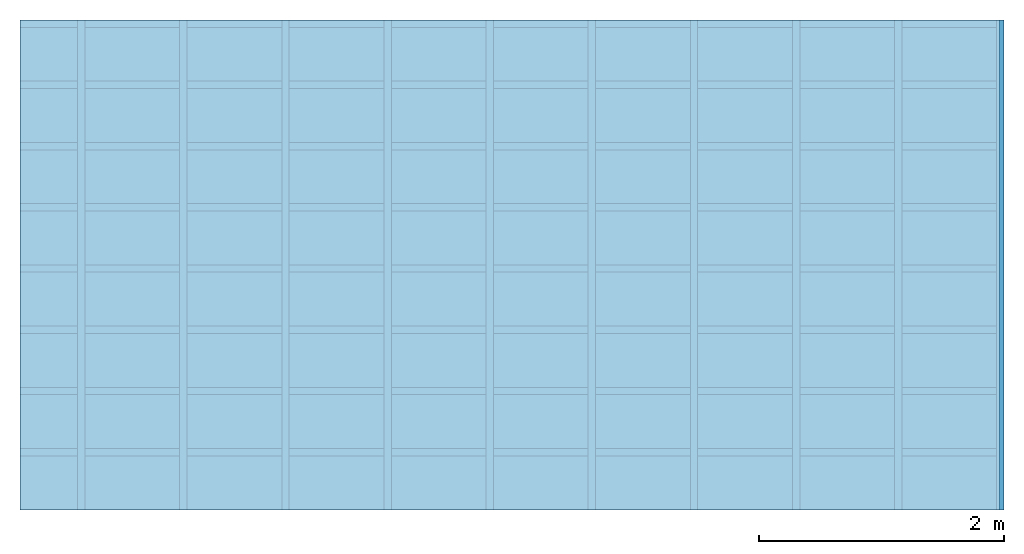
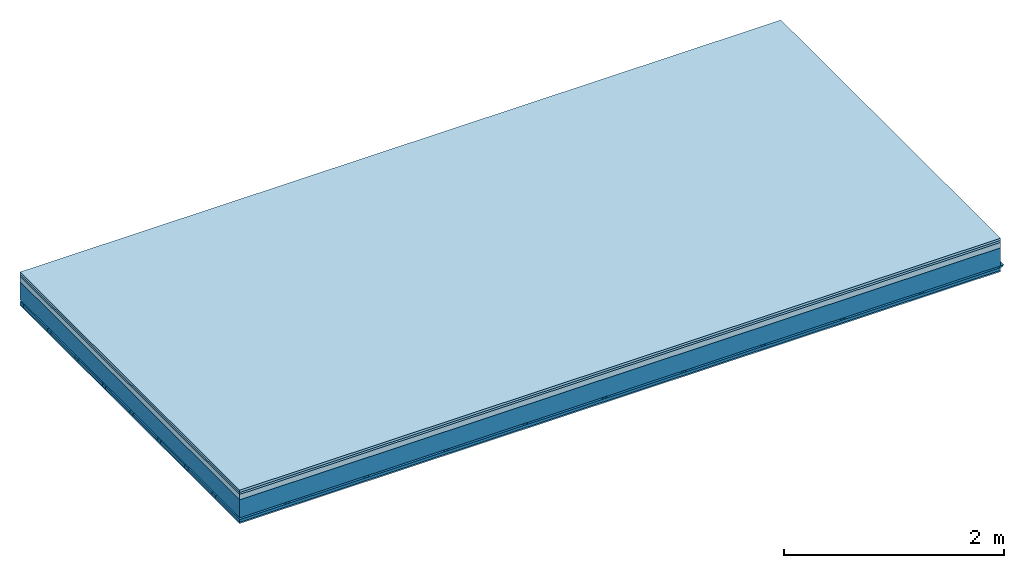
# One storey: 4 members, 4 plates, 1 element without a shape of its own.
"""IFC4 building model written with IfcOpenShell, lengths in metres."""

from ifc_helpers import new_model, si_unit, derived_unit, direction, frame, frame_2d, origin, origin_with_axes, place, context, project, spatial, polyline, rectangle, outline, extrude, material, layer, layer_set, type_object, element, aggregate, save


model = new_model("IFC4")

# Units and contexts
plan_context = context("Plan", 3, precision=1e-05, world=origin(), true_north=direction((0.0, 1.0)))
model_context = context("Model", 3, precision=1e-05, world=origin(), true_north=direction((0.0, 1.0)))
ifc_project = project(units=[si_unit("LENGTHUNIT", "METRE"), derived_unit("SOUNDPRESSUREUNIT", [(si_unit("PRESSUREUNIT", "PASCAL", prefix="MICRO"), 0)]), si_unit("ENERGYUNIT", "JOULE", prefix="MEGA"), si_unit("MASSUNIT", "GRAM", prefix="KILO"), derived_unit("THERMALTRANSMITTANCEUNIT", [(si_unit("POWERUNIT", "WATT"), 1), (si_unit("AREAUNIT", "SQUARE_METRE"), -1), (si_unit("THERMODYNAMICTEMPERATUREUNIT", "KELVIN"), -1)]), derived_unit("AREADENSITYUNIT", [(si_unit("MASSUNIT", "GRAM", prefix="KILO"), 1), (si_unit("AREAUNIT", "SQUARE_METRE"), -1)]), derived_unit("USERDEFINED", [(si_unit("ENERGYUNIT", "JOULE", prefix="MEGA"), 1), (si_unit("AREAUNIT", "SQUARE_METRE"), -1)])], contexts=[plan_context, model_context])

# Site, building, storey
site = spatial("IfcSite", under=ifc_project)
building_placement = place(None, origin())
building = spatial("IfcBuilding", under=site, at=building_placement)
storey_placement = place(building_placement, origin())
storey = spatial("IfcBuildingStorey", under=building, at=storey_placement)

# Slab, members, plates
ifc_material_1 = material(Name="Floor heating system Therm38 longitudinal", Category="03.007")
ifc_layer_1 = layer(ifc_material_1, 0.025, Name="On-material")
ifc_material_2 = material(Category="10.009")
ifc_layer_2 = layer(ifc_material_2, 0.022, Name="Impact sound insulation")
ifc_material_3 = material(Category="03.011")
ifc_layer_3 = layer(ifc_material_3, 0.06, Name="on Supporting structure")
ifc_layer_4 = layer(None, 0.2, Name="Supporting structure")
ifc_material_4 = material(Name="no composite action")
ifc_layer_5 = layer(ifc_material_4, 0.0, Name="Bond")
ifc_layer_6 = layer(None, 0.02, Name="Coupling")
ifc_layer_7 = layer(None, 0.03, Name="Battens / profiles")
ifc_material_5 = material(Category="03.007")
ifc_layer_8 = layer(ifc_material_5, 0.015, Name="Ceiling covering 1st layer")
ifc_material_6 = material(Name="Glued joints")
ifc_layer_9 = layer(ifc_material_6, 0.0, Name="Surface / treatment")
ifc_layer_set = layer_set([ifc_layer_1, ifc_layer_2, ifc_layer_3, ifc_layer_4, ifc_layer_5, ifc_layer_6, ifc_layer_7, ifc_layer_8, ifc_layer_9])
slab_type = type_object("IfcSlabType", Name="A1126", PredefinedType="NOTDEFINED", material=ifc_layer_set)
slab_placement = place(None, frame((0.0, 0.0, 0.0), z_axis=(0.0, 0.0, -1.0), x_axis=(1.0, 0.0, 0.0)))
slab = element("IfcSlab", 1, at=slab_placement, inside=storey, type_object=slab_type, material=ifc_layer_set, Name="Slab #1")
ifc_material_7 = material()
member_1_placement = place(slab_placement, origin())
member_1 = element("IfcMember", 2, at=member_1_placement, material=ifc_material_7, Name="Supporting structure", context=plan_context, shape_type="SweptSolid", body=[
    extrude(rectangle(XDim=1.0, YDim=0.2, at=frame_2d((0.5, 0.1), x_axis=(1.0, 0.0))), frame((0.0, 4.0, 0.107), z_axis=(0.0, -1.0, 0.0), x_axis=(1.0, 0.0, 0.0)), (0.0, 0.0, 1.0), 4.0),
    extrude(rectangle(XDim=1.0, YDim=0.2, at=frame_2d((0.5, 0.1), x_axis=(1.0, 0.0))), frame((1.0, 4.0, 0.107), z_axis=(0.0, -1.0, 0.0), x_axis=(1.0, 0.0, 0.0)), (0.0, 0.0, 1.0), 4.0),
    extrude(rectangle(XDim=1.0, YDim=0.2, at=frame_2d((0.5, 0.1), x_axis=(1.0, 0.0))), frame((2.0, 4.0, 0.107), z_axis=(0.0, -1.0, 0.0), x_axis=(1.0, 0.0, 0.0)), (0.0, 0.0, 1.0), 4.0),
    extrude(rectangle(XDim=1.0, YDim=0.2, at=frame_2d((0.5, 0.1), x_axis=(1.0, 0.0))), frame((3.0, 4.0, 0.107), z_axis=(0.0, -1.0, 0.0), x_axis=(1.0, 0.0, 0.0)), (0.0, 0.0, 1.0), 4.0),
    extrude(rectangle(XDim=1.0, YDim=0.2, at=frame_2d((0.5, 0.1), x_axis=(1.0, 0.0))), frame((4.0, 4.0, 0.107), z_axis=(0.0, -1.0, 0.0), x_axis=(1.0, 0.0, 0.0)), (0.0, 0.0, 1.0), 4.0),
    extrude(rectangle(XDim=1.0, YDim=0.2, at=frame_2d((0.5, 0.1), x_axis=(1.0, 0.0))), frame((5.0, 4.0, 0.107), z_axis=(0.0, -1.0, 0.0), x_axis=(1.0, 0.0, 0.0)), (0.0, 0.0, 1.0), 4.0),
    extrude(rectangle(XDim=1.0, YDim=0.2, at=frame_2d((0.5, 0.1), x_axis=(1.0, 0.0))), frame((6.0, 4.0, 0.107), z_axis=(0.0, -1.0, 0.0), x_axis=(1.0, 0.0, 0.0)), (0.0, 0.0, 1.0), 4.0),
    extrude(rectangle(XDim=1.0, YDim=0.2, at=frame_2d((0.5, 0.1), x_axis=(1.0, 0.0))), frame((7.0, 4.0, 0.107), z_axis=(0.0, -1.0, 0.0), x_axis=(1.0, 0.0, 0.0)), (0.0, 0.0, 1.0), 4.0),
])
ifc_material_8 = material()
member_2_placement = place(slab_placement, origin())
member_2 = element("IfcMember", 3, at=member_2_placement, material=ifc_material_8, Name="Coupling", context=plan_context, shape_type="SweptSolid", body=[
    extrude(outline(polyline([(0.0, 0.0), (0.06, 0.0), (0.04, 0.02), (0.02, 0.02), (0.0, 0.0)])), frame((0.47, 4.0, 0.307), z_axis=(0.0, -1.0, 0.0), x_axis=(1.0, 0.0, 0.0)), (0.0, 0.0, 1.0), 4.0),
    extrude(outline(polyline([(0.0, 0.0), (0.06, 0.0), (0.04, 0.02), (0.02, 0.02), (0.0, 0.0)])), frame((1.304, 4.0, 0.307), z_axis=(0.0, -1.0, 0.0), x_axis=(1.0, 0.0, 0.0)), (0.0, 0.0, 1.0), 4.0),
    extrude(outline(polyline([(0.0, 0.0), (0.06, 0.0), (0.04, 0.02), (0.02, 0.02), (0.0, 0.0)])), frame((2.138, 4.0, 0.307), z_axis=(0.0, -1.0, 0.0), x_axis=(1.0, 0.0, 0.0)), (0.0, 0.0, 1.0), 4.0),
    extrude(outline(polyline([(0.0, 0.0), (0.06, 0.0), (0.04, 0.02), (0.02, 0.02), (0.0, 0.0)])), frame((2.972, 4.0, 0.307), z_axis=(0.0, -1.0, 0.0), x_axis=(1.0, 0.0, 0.0)), (0.0, 0.0, 1.0), 4.0),
    extrude(outline(polyline([(0.0, 0.0), (0.06, 0.0), (0.04, 0.02), (0.02, 0.02), (0.0, 0.0)])), frame((3.806, 4.0, 0.307), z_axis=(0.0, -1.0, 0.0), x_axis=(1.0, 0.0, 0.0)), (0.0, 0.0, 1.0), 4.0),
    extrude(outline(polyline([(0.0, 0.0), (0.06, 0.0), (0.04, 0.02), (0.02, 0.02), (0.0, 0.0)])), frame((4.64, 4.0, 0.307), z_axis=(0.0, -1.0, 0.0), x_axis=(1.0, 0.0, 0.0)), (0.0, 0.0, 1.0), 4.0),
    extrude(outline(polyline([(0.0, 0.0), (0.06, 0.0), (0.04, 0.02), (0.02, 0.02), (0.0, 0.0)])), frame((5.474, 4.0, 0.307), z_axis=(0.0, -1.0, 0.0), x_axis=(1.0, 0.0, 0.0)), (0.0, 0.0, 1.0), 4.0),
    extrude(outline(polyline([(0.0, 0.0), (0.06, 0.0), (0.04, 0.02), (0.02, 0.02), (0.0, 0.0)])), frame((6.308, 4.0, 0.307), z_axis=(0.0, -1.0, 0.0), x_axis=(1.0, 0.0, 0.0)), (0.0, 0.0, 1.0), 4.0),
    extrude(outline(polyline([(0.0, 0.0), (0.06, 0.0), (0.04, 0.02), (0.02, 0.02), (0.0, 0.0)])), frame((7.142, 4.0, 0.307), z_axis=(0.0, -1.0, 0.0), x_axis=(1.0, 0.0, 0.0)), (0.0, 0.0, 1.0), 4.0),
    extrude(outline(polyline([(0.0, 0.0), (0.06, 0.0), (0.04, 0.02), (0.02, 0.02), (0.0, 0.0)])), frame((7.976, 4.0, 0.307), z_axis=(0.0, -1.0, 0.0), x_axis=(1.0, 0.0, 0.0)), (0.0, 0.0, 1.0), 4.0),
])
ifc_material_9 = material()
member_3_placement = place(slab_placement, origin())
member_3 = element("IfcMember", 4, at=member_3_placement, material=ifc_material_9, Name="Battens / profiles", context=plan_context, shape_type="SweptSolid", body=[
    extrude(rectangle(XDim=0.06, YDim=0.03, at=frame_2d((0.03, 0.015), x_axis=(1.0, 0.0))), frame((0.0, 0.0, 0.327), z_axis=(1.0, 0.0, 0.0), x_axis=(0.0, 1.0, 0.0)), (0.0, 0.0, 1.0), 8.0),
    extrude(rectangle(XDim=0.06, YDim=0.03, at=frame_2d((0.03, 0.015), x_axis=(1.0, 0.0))), frame((0.0, 0.5, 0.327), z_axis=(1.0, 0.0, 0.0), x_axis=(0.0, 1.0, 0.0)), (0.0, 0.0, 1.0), 8.0),
    extrude(rectangle(XDim=0.06, YDim=0.03, at=frame_2d((0.03, 0.015), x_axis=(1.0, 0.0))), frame((0.0, 1.0, 0.327), z_axis=(1.0, 0.0, 0.0), x_axis=(0.0, 1.0, 0.0)), (0.0, 0.0, 1.0), 8.0),
    extrude(rectangle(XDim=0.06, YDim=0.03, at=frame_2d((0.03, 0.015), x_axis=(1.0, 0.0))), frame((0.0, 1.5, 0.327), z_axis=(1.0, 0.0, 0.0), x_axis=(0.0, 1.0, 0.0)), (0.0, 0.0, 1.0), 8.0),
    extrude(rectangle(XDim=0.06, YDim=0.03, at=frame_2d((0.03, 0.015), x_axis=(1.0, 0.0))), frame((0.0, 2.0, 0.327), z_axis=(1.0, 0.0, 0.0), x_axis=(0.0, 1.0, 0.0)), (0.0, 0.0, 1.0), 8.0),
    extrude(rectangle(XDim=0.06, YDim=0.03, at=frame_2d((0.03, 0.015), x_axis=(1.0, 0.0))), frame((0.0, 2.5, 0.327), z_axis=(1.0, 0.0, 0.0), x_axis=(0.0, 1.0, 0.0)), (0.0, 0.0, 1.0), 8.0),
    extrude(rectangle(XDim=0.06, YDim=0.03, at=frame_2d((0.03, 0.015), x_axis=(1.0, 0.0))), frame((0.0, 3.0, 0.327), z_axis=(1.0, 0.0, 0.0), x_axis=(0.0, 1.0, 0.0)), (0.0, 0.0, 1.0), 8.0),
    extrude(rectangle(XDim=0.06, YDim=0.03, at=frame_2d((0.03, 0.015), x_axis=(1.0, 0.0))), frame((0.0, 3.5, 0.327), z_axis=(1.0, 0.0, 0.0), x_axis=(0.0, 1.0, 0.0)), (0.0, 0.0, 1.0), 8.0),
])
ifc_material_10 = material()
member_4_placement = place(slab_placement, origin())
member_4 = element("IfcMember", 5, at=member_4_placement, material=ifc_material_10, Name="Cavity", context=plan_context, shape_type="SweptSolid", body=[
    extrude(rectangle(XDim=0.44, YDim=0.03, at=frame_2d((0.22, 0.015), x_axis=(1.0, 0.0))), frame((0.0, 0.06, 0.327), z_axis=(1.0, 0.0, 0.0), x_axis=(0.0, 1.0, 0.0)), (0.0, 0.0, 1.0), 8.0),
    extrude(rectangle(XDim=0.44, YDim=0.03, at=frame_2d((0.22, 0.015), x_axis=(1.0, 0.0))), frame((0.0, 0.56, 0.327), z_axis=(1.0, 0.0, 0.0), x_axis=(0.0, 1.0, 0.0)), (0.0, 0.0, 1.0), 8.0),
    extrude(rectangle(XDim=0.44, YDim=0.03, at=frame_2d((0.22, 0.015), x_axis=(1.0, 0.0))), frame((0.0, 1.06, 0.327), z_axis=(1.0, 0.0, 0.0), x_axis=(0.0, 1.0, 0.0)), (0.0, 0.0, 1.0), 8.0),
    extrude(rectangle(XDim=0.44, YDim=0.03, at=frame_2d((0.22, 0.015), x_axis=(1.0, 0.0))), frame((0.0, 1.56, 0.327), z_axis=(1.0, 0.0, 0.0), x_axis=(0.0, 1.0, 0.0)), (0.0, 0.0, 1.0), 8.0),
    extrude(rectangle(XDim=0.44, YDim=0.03, at=frame_2d((0.22, 0.015), x_axis=(1.0, 0.0))), frame((0.0, 2.06, 0.327), z_axis=(1.0, 0.0, 0.0), x_axis=(0.0, 1.0, 0.0)), (0.0, 0.0, 1.0), 8.0),
    extrude(rectangle(XDim=0.44, YDim=0.03, at=frame_2d((0.22, 0.015), x_axis=(1.0, 0.0))), frame((0.0, 2.56, 0.327), z_axis=(1.0, 0.0, 0.0), x_axis=(0.0, 1.0, 0.0)), (0.0, 0.0, 1.0), 8.0),
    extrude(rectangle(XDim=0.44, YDim=0.03, at=frame_2d((0.22, 0.015), x_axis=(1.0, 0.0))), frame((0.0, 3.06, 0.327), z_axis=(1.0, 0.0, 0.0), x_axis=(0.0, 1.0, 0.0)), (0.0, 0.0, 1.0), 8.0),
    extrude(rectangle(XDim=0.44, YDim=0.03, at=frame_2d((0.22, 0.015), x_axis=(1.0, 0.0))), frame((0.0, 3.56, 0.327), z_axis=(1.0, 0.0, 0.0), x_axis=(0.0, 1.0, 0.0)), (0.0, 0.0, 1.0), 8.0),
])
plate_1_placement = place(slab_placement, origin())
plate_1 = element("IfcPlate", 6, at=plate_1_placement, material=ifc_material_1, Name="On-material", context=plan_context, shape_type="SweptSolid", body=[
    extrude(rectangle(XDim=8.0, YDim=4.0, at=frame_2d((4.0, 2.0), x_axis=(1.0, 0.0))), origin_with_axes(), (0.0, 0.0, 1.0), 0.025),
])
plate_2_placement = place(slab_placement, origin())
plate_2 = element("IfcPlate", 7, at=plate_2_placement, material=ifc_material_2, Name="Impact sound insulation", context=plan_context, shape_type="SweptSolid", body=[
    extrude(rectangle(XDim=8.0, YDim=4.0, at=frame_2d((4.0, 2.0), x_axis=(1.0, 0.0))), frame((0.0, 0.0, 0.025), z_axis=(0.0, 0.0, 1.0), x_axis=(1.0, 0.0, 0.0)), (0.0, 0.0, 1.0), 0.022),
])
plate_3_placement = place(slab_placement, origin())
plate_3 = element("IfcPlate", 8, at=plate_3_placement, material=ifc_material_3, Name="on Supporting structure", context=plan_context, shape_type="SweptSolid", body=[
    extrude(rectangle(XDim=8.0, YDim=4.0, at=frame_2d((4.0, 2.0), x_axis=(1.0, 0.0))), frame((0.0, 0.0, 0.047), z_axis=(0.0, 0.0, 1.0), x_axis=(1.0, 0.0, 0.0)), (0.0, 0.0, 1.0), 0.06),
])
plate_4_placement = place(slab_placement, origin())
plate_4 = element("IfcPlate", 9, at=plate_4_placement, material=ifc_material_5, Name="Ceiling covering 1st layer", context=plan_context, shape_type="SweptSolid", body=[
    extrude(rectangle(XDim=8.0, YDim=4.0, at=frame_2d((4.0, 2.0), x_axis=(1.0, 0.0))), frame((0.0, 0.0, 0.357), z_axis=(0.0, 0.0, 1.0), x_axis=(1.0, 0.0, 0.0)), (0.0, 0.0, 1.0), 0.015),
])
aggregate(slab, [plate_1, plate_2, plate_3, member_1, member_2, member_3, member_4, plate_4])

save(model, "model.ifc")
